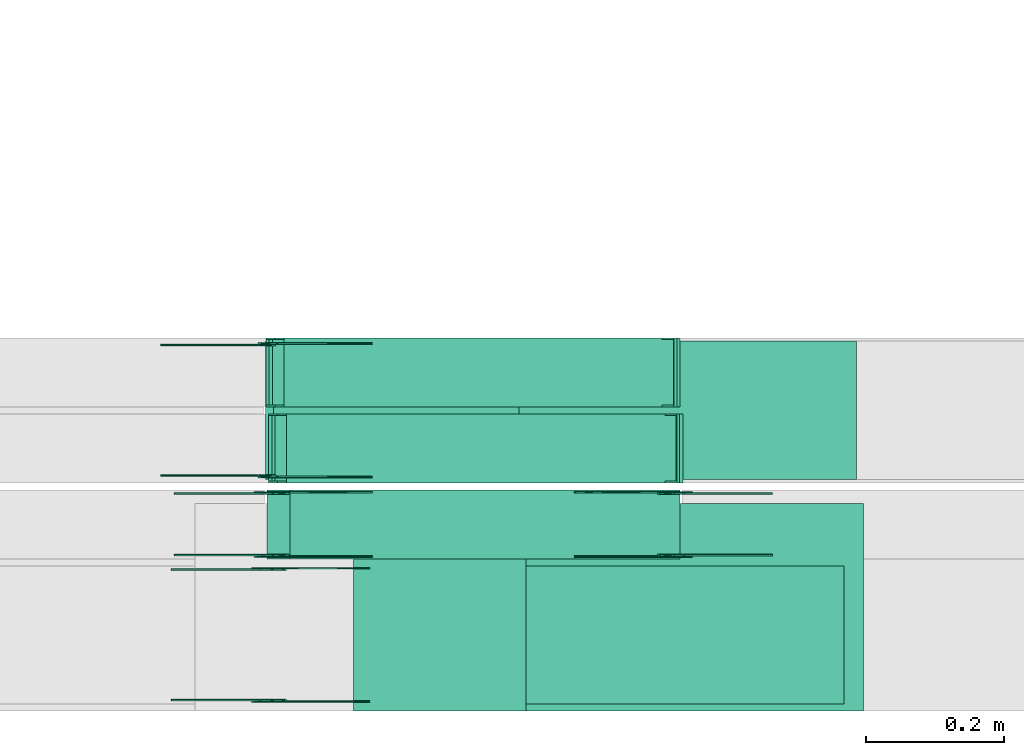
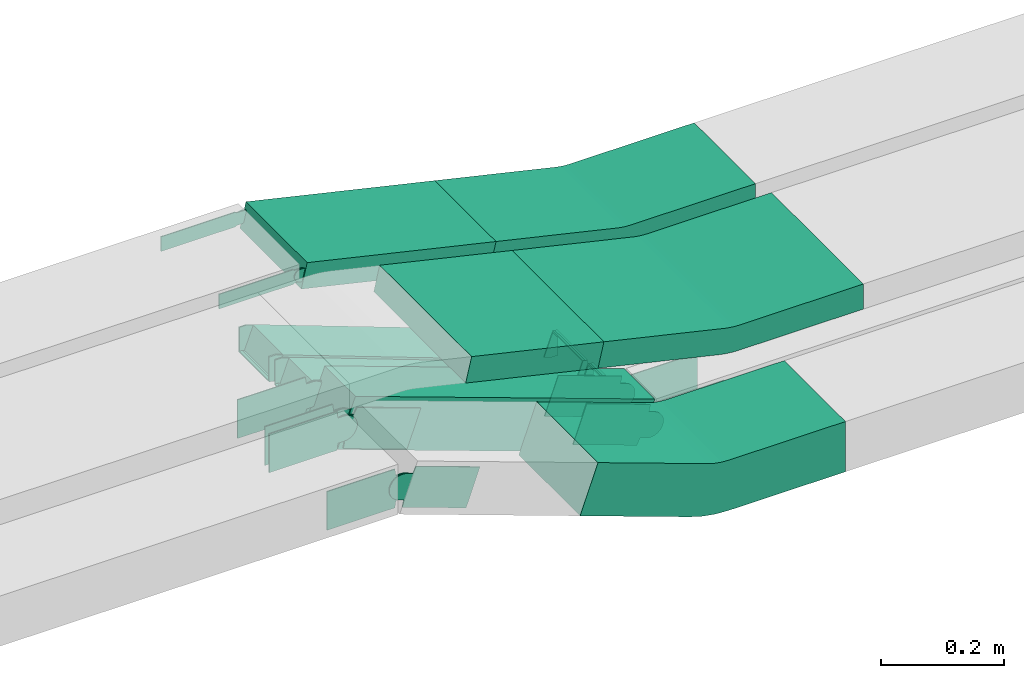
# One storey, part 13 of 31: 23 flow fittings, 5 flow segments.
"""IFC2X3 building model written with IfcOpenShell, lengths in millimetres."""

from ifc_helpers import new_model, entity, si_unit, converted_unit, derived_unit, direction, frame, frame_2d, origin, origin_2d_with_axis, place, context, subcontext, project, spatial, polyline, circle_curve, parameter, trimmed, segment, composite_curve, rectangle, outline, extrude, faceted_brep, source, transform, mapped, material, type_object, type_shapes, element, save


model = new_model("IFC2X3")

# Units and contexts
model_context = context("Model", 3, precision=0.01, world=origin(), true_north=direction((6.12303176911189e-17, 1.0)))
body_context = subcontext(model_context, "Body", "Model", "MODEL_VIEW")
ifc_project = project(units=[si_unit("LENGTHUNIT", "METRE", prefix="MILLI"), si_unit("AREAUNIT", "SQUARE_METRE"), si_unit("VOLUMEUNIT", "CUBIC_METRE"), converted_unit("PLANEANGLEUNIT", "DEGREE", entity("IfcRatioMeasure", 0.0174532925199433), si_unit("PLANEANGLEUNIT", "RADIAN"), dimensions=[0, 0, 0, 0, 0, 0, 0]), si_unit("MASSUNIT", "GRAM", prefix="KILO"), derived_unit("MASSDENSITYUNIT", [(si_unit("MASSUNIT", "GRAM", prefix="KILO"), 1), (si_unit("LENGTHUNIT", "METRE"), -3)]), derived_unit("MOMENTOFINERTIAUNIT", [(si_unit("LENGTHUNIT", "METRE"), 4)]), si_unit("TIMEUNIT", "SECOND"), si_unit("FREQUENCYUNIT", "HERTZ"), si_unit("THERMODYNAMICTEMPERATUREUNIT", "DEGREE_CELSIUS"), derived_unit("THERMALTRANSMITTANCEUNIT", [(si_unit("MASSUNIT", "GRAM", prefix="KILO"), 1), (si_unit("THERMODYNAMICTEMPERATUREUNIT", "KELVIN"), -1), (si_unit("TIMEUNIT", "SECOND"), -3)]), derived_unit("VOLUMETRICFLOWRATEUNIT", [(si_unit("LENGTHUNIT", "METRE"), 3), (si_unit("TIMEUNIT", "SECOND"), -1)]), derived_unit("MASSFLOWRATEUNIT", [(si_unit("MASSUNIT", "GRAM", prefix="KILO"), 1), (si_unit("TIMEUNIT", "SECOND"), -1)]), derived_unit("ROTATIONALFREQUENCYUNIT", [(si_unit("TIMEUNIT", "SECOND"), -1)]), si_unit("ELECTRICCURRENTUNIT", "AMPERE"), si_unit("ELECTRICVOLTAGEUNIT", "VOLT"), si_unit("POWERUNIT", "WATT"), si_unit("FORCEUNIT", "NEWTON", prefix="KILO"), si_unit("ILLUMINANCEUNIT", "LUX"), si_unit("LUMINOUSFLUXUNIT", "LUMEN"), si_unit("LUMINOUSINTENSITYUNIT", "CANDELA"), derived_unit("USERDEFINED", [(si_unit("MASSUNIT", "GRAM", prefix="KILO"), -1), (si_unit("LENGTHUNIT", "METRE"), -2), (si_unit("TIMEUNIT", "SECOND"), 3), (si_unit("LUMINOUSFLUXUNIT", "LUMEN"), 1)]), derived_unit("LINEARVELOCITYUNIT", [(si_unit("LENGTHUNIT", "METRE"), 1), (si_unit("TIMEUNIT", "SECOND"), -1)]), si_unit("PRESSUREUNIT", "PASCAL"), derived_unit("USERDEFINED", [(si_unit("LENGTHUNIT", "METRE"), -2), (si_unit("MASSUNIT", "GRAM", prefix="KILO"), 1), (si_unit("TIMEUNIT", "SECOND"), -2)]), derived_unit("LINEARFORCEUNIT", [(si_unit("MASSUNIT", "GRAM", prefix="KILO"), 1), (si_unit("LENGTHUNIT", "METRE"), 1), (si_unit("TIMEUNIT", "SECOND"), -2), (si_unit("LENGTHUNIT", "METRE"), -1)]), derived_unit("PLANARFORCEUNIT", [(si_unit("MASSUNIT", "GRAM", prefix="KILO"), 1), (si_unit("LENGTHUNIT", "METRE"), 1), (si_unit("TIMEUNIT", "SECOND"), -2), (si_unit("LENGTHUNIT", "METRE"), -2)])], contexts=[model_context])

# Site, building, storey
site_placement = place(None, frame((0.0, -0.00077364408347762, 0.0)))
site = spatial("IfcSite", under=ifc_project, at=site_placement, CompositionType="ELEMENT")
building_placement = place(site_placement, origin())
building = spatial("IfcBuilding", under=site, at=building_placement, CompositionType="ELEMENT")
storey_placement = place(building_placement, frame((0.0, 0.0, 15900.0)))
storey = spatial("IfcBuildingStorey", under=building, at=storey_placement, CompositionType="ELEMENT", Elevation=15900.0)

# Flow segments
cable_carrier_segment_type = type_object("IfcCableCarrierSegmentType", PredefinedType="CABLETRAYSEGMENT")
flow_segment_1_placement = place(storey_placement, frame((42482.3180305908, 8215.14880665484, 2877.20647019487)))
element("IfcFlowSegment", 1, at=flow_segment_1_placement, inside=storey, type_object=cable_carrier_segment_type, context=body_context, shape_type="SweptSolid", body=[
    extrude(rectangle(XDim=49.9999999999981, YDim=255.770491519839, at=frame_2d((0.0, 0.0), x_axis=(0.0, 1.0))), frame((130.22711908791, 0.0, 53.2392767577453), z_axis=(0.0, 1.0, 0.0), x_axis=(-0.974157642890838, 0.0, 0.225869180716108)), (0.0, 0.0, 1.0), 299.999999999999),
])
flow_segment_2_placement = place(storey_placement, frame((42367.697045461, 8434.96624585786, 2506.47701991748)))
element("IfcFlowSegment", 2, at=flow_segment_2_placement, inside=storey, type_object=cable_carrier_segment_type, context=body_context, shape_type="SweptSolid", body=[
    extrude(rectangle(XDim=100.000000000003, YDim=99.9999999999989, at=origin_2d_with_axis()), frame((16.9237303605876, 50.0, 249.997183871926), z_axis=(0.940975525862782, 0.0, -0.338474607211915), x_axis=(0.338474607211915, 0.0, 0.940975525862782)), (0.0, 0.0, 1.0), 599.59714334412),
])
flow_segment_3_placement = place(storey_placement, frame((42366.014324896, 8550.14880665484, 2877.20647019487)))
element("IfcFlowSegment", 3, at=flow_segment_3_placement, inside=storey, type_object=cable_carrier_segment_type, context=body_context, shape_type="SweptSolid", body=[
    extrude(rectangle(XDim=50.0000000000021, YDim=200.0, at=frame_2d((-9.78772618509538e-13, 1.08713038571295e-12), x_axis=(1.0, 0.0))), frame((5.6467295179074, 100.0, 106.818232268258), z_axis=(0.974157642890797, 0.0, -0.225869180716286), x_axis=(0.225869180716286, 0.0, 0.974157642890797)), (0.0, 0.0, 1.0), 365.097579645558),
])
flow_segment_4_placement = place(storey_placement, frame((42378.6912123669, 8544.96624585788, 2499.72488286839)))
element("IfcFlowSegment", 4, at=flow_segment_4_placement, inside=storey, type_object=cable_carrier_segment_type, context=body_context, shape_type="SweptSolid", body=[
    extrude(rectangle(XDim=50.0000000000049, YDim=100.000000000001, at=frame_2d((-1.01429975529754e-12, 0.0), x_axis=(1.0, 0.0))), frame((8.68410762290543, 50.0, 232.798975562678), z_axis=(0.937730259547007, 0.0, -0.347364304916183), x_axis=(0.347364304916183, 0.0, 0.937730259547007)), (0.0, 0.0, 1.0), 602.697848083628),
])
flow_segment_5_placement = place(storey_placement, frame((42374.9501718794, 8654.96624585788, 2499.69389983)))
element("IfcFlowSegment", 5, at=flow_segment_5_placement, inside=storey, type_object=cable_carrier_segment_type, context=body_context, shape_type="SweptSolid", body=[
    extrude(rectangle(XDim=50.0000000000049, YDim=100.000000000001, at=frame_2d((-1.01429975529754e-12, 0.0), x_axis=(1.0, 0.0))), frame((8.68410762289677, 50.0, 232.794724098533), z_axis=(0.937730259547007, 0.0, -0.347364304916183), x_axis=(0.347364304916183, 0.0, 0.937730259547007)), (0.0, 0.0, 1.0), 602.685608875145),
])

# Flow fittings
ifc_material_1 = material()
cable_carrier_fitting_type_1 = type_object("IfcCableCarrierFittingType", Name="470_DKC_S5_CS 90 internal vertical angle:-", PredefinedType="NOTDEFINED", material=ifc_material_1)
shared_shape_1 = source(origin(), body_context, "Body", "SweptSolid", [
    extrude(outline(composite_curve([segment(polyline([(-248.690961479511, -40.0445853156089), (-14.2965164116635, -40.0445853156089)]), True, "CONTINUOUS"), segment(trimmed(circle_curve(frame_2d((-14.2965164116638, 124.95541468439), x_axis=(0.0, -1.0)), 164.999999999999), [parameter(0.0)], [parameter(13.0539943692735)], True, "PARAMETER"), True, "CONTINUOUS"), segment(polyline([(22.9718984064878, -35.7805963925986), (251.309038520489, 17.1618848792738)]), True, "CONTINUOUS"), segment(polyline([(251.309038520489, 17.1618848792738), (240.015579484686, 65.8697670238164)]), True, "CONTINUOUS"), segment(polyline([(240.015579484686, 65.8697670238164), (11.6784393706841, 12.927285751944)]), True, "CONTINUOUS"), segment(trimmed(circle_curve(frame_2d((-14.2965164116638, 124.95541468439), x_axis=(0.0, -1.0)), 114.999999999999), [parameter(0.0)], [parameter(13.0539943692735)], True, "PARAMETER"), False, "CONTINUOUS"), segment(polyline([(-14.2965164116635, 9.95541468439133), (-248.690961479511, 9.95541468439135)]), True, "CONTINUOUS"), segment(polyline([(-248.690961479511, 9.95541468439135), (-248.690961479511, -40.0445853156089)]), True, "CONTINUOUS")], self_intersect=False)), frame((-1.72129524289458, 15.0445853156017, -150.0)), (0.0, 0.0, 1.0), 300.0),
])
type_shapes(cable_carrier_fitting_type_1, [shared_shape_1])
flow_fitting_1_placement = place(storey_placement, frame((42981.0665530085, 8365.14880665484, 2845.0), z_axis=(0.0, 1.0, 0.0), x_axis=(-1.0, 0.0, 0.0)))
element("IfcFlowFitting", 6, at=flow_fitting_1_placement, inside=storey, type_object=cable_carrier_fitting_type_1, material=ifc_material_1, Name="470_DKC_S5_CS 90 internal vertical angle:-", ObjectType="470_DKC_S5_CS 90 internal vertical angle:-", context=body_context, shape_type="MappedRepresentation", body=[
    mapped(shared_shape_1, transform((0.0, 0.0, 0.0), scale=1.0)),
])
cable_carrier_fitting_type_2 = type_object("IfcCableCarrierFittingType", Name="470_DKC_S5_CS 90 internal vertical angle:-", PredefinedType="NOTDEFINED", material=ifc_material_1)
shared_shape_2 = source(origin(), body_context, "Body", "SweptSolid", [
    extrude(outline(composite_curve([segment(polyline([(-248.690961479511, -40.0445853156089), (-14.2965164116635, -40.0445853156089)]), True, "CONTINUOUS"), segment(trimmed(circle_curve(frame_2d((-14.2965164116638, 124.95541468439), x_axis=(0.0, -1.0)), 164.999999999999), [parameter(0.0)], [parameter(13.0539943692735)], True, "PARAMETER"), True, "CONTINUOUS"), segment(polyline([(22.9718984064878, -35.7805963925986), (251.309038520489, 17.1618848792738)]), True, "CONTINUOUS"), segment(polyline([(251.309038520489, 17.1618848792738), (240.015579484686, 65.8697670238164)]), True, "CONTINUOUS"), segment(polyline([(240.015579484686, 65.8697670238164), (11.6784393706841, 12.9272857519439)]), True, "CONTINUOUS"), segment(trimmed(circle_curve(frame_2d((-14.2965164116638, 124.95541468439), x_axis=(0.0, -1.0)), 114.999999999999), [parameter(0.0)], [parameter(13.0539943692735)], True, "PARAMETER"), False, "CONTINUOUS"), segment(polyline([(-14.2965164116635, 9.95541468439131), (-248.690961479511, 9.95541468439132)]), True, "CONTINUOUS"), segment(polyline([(-248.690961479511, 9.95541468439132), (-248.690961479511, -40.0445853156089)]), True, "CONTINUOUS")], self_intersect=False)), frame((-1.72129524289457, 15.0445853156016, -100.0)), (0.0, 0.0, 1.0), 200.0),
])
type_shapes(cable_carrier_fitting_type_2, [shared_shape_2])
flow_fitting_2_placement = place(storey_placement, frame((42971.2646657863, 8650.14880665484, 2845.0), z_axis=(0.0, 1.0, 0.0), x_axis=(-1.0, 0.0, 0.0)))
element("IfcFlowFitting", 7, at=flow_fitting_2_placement, inside=storey, type_object=cable_carrier_fitting_type_2, material=ifc_material_1, Name="470_DKC_S5_CS 90 internal vertical angle:-", ObjectType="470_DKC_S5_CS 90 internal vertical angle:-", context=body_context, shape_type="MappedRepresentation", body=[
    mapped(shared_shape_2, transform((0.0, 0.0, 0.0), scale=1.0)),
])
cable_carrier_fitting_type_3 = type_object("IfcCableCarrierFittingType", PredefinedType="NOTDEFINED", material=ifc_material_1)
shared_shape_3 = source(origin(), body_context, "Body", "Brep", [
    faceted_brep([(-8.96317491056018, 25.0, 50.0), (-8.96317491056018, 25.0, -50.0), (-8.96317491056034, -25.0, -50.0), (-8.96317491056034, -25.0, -47.4600000101565), (-8.96317491056018, 22.46000001016, -47.4600000101565), (-8.96317491056018, 22.46000001016, 47.4600000101635), (-8.96317491056034, -25.0, 47.4600000101635), (-8.96317491056034, -25.0, 50.0), (-0.279067287656983, 26.5567435113238, 50.0), (17.0891479581493, -20.3297694660276, 50.0), (17.0891479581493, -20.3297694660276, 47.4600000101635), (0.603238043300752, 24.1749086616017, 47.4600000101635), (0.60323804330075, 24.1749086616017, -47.4600000101565), (17.0891479581493, -20.3297694660276, -47.4600000101565), (17.0891479581493, -20.3297694660276, -50.0), (-0.279067287656982, 26.5567435113238, -50.0), (-4.48158745527978, 25.0, 50.0), (-4.48158745527987, 25.0, -50.0), (4.48158745528077, -25.0, -50.0), (4.48158745528077, -25.0, -47.4600000101565), (-4.0262581716447, 22.46000001016, -47.4600000101565), (-4.0262581716447, 22.46000001016, 47.4600000101635), (4.48158745528077, -25.0, 47.4600000101635), (4.48158745528077, -25.0, 50.0)], [[[0, 1, 2, 3, 4, 5, 6, 7]], [[8, 9, 10, 11, 12, 13, 14, 15]], [[1, 0, 16, 17]], [[2, 1, 17, 15, 14, 18]], [[3, 2, 18, 19]], [[4, 3, 19, 13, 12, 20]], [[5, 4, 20, 21]], [[6, 5, 21, 11, 10, 22]], [[7, 6, 22, 23]], [[0, 7, 23, 9, 8, 16]], [[17, 16, 8, 15]], [[19, 18, 14, 13]], [[21, 20, 12, 11]], [[23, 22, 10, 9]]]),
])
type_shapes(cable_carrier_fitting_type_3, [shared_shape_3])
for number, where, z_axis, x_axis in (
    (8, (42378.9702796546, 8594.96624585789, 2735.63734545371), (0.0, 1.0, 0.0), (1.0, 0.0, 0.0)),
    (9, (42375.229239167, 8704.96624585788, 2735.60211095118), (0.0, 1.0, 0.0), (1.0, 0.0, 0.0)),
    (10, (42960.948369837, 8594.96624585789, 2520.05465233443), (0.0, -1.0, 0.0), (0.937730259547021, 0.0, -0.347364304916146)),
    (11, (42957.1958522733, 8704.96624585788, 2520.02366929604), (0.0, -1.0, 0.0), (0.937730259547021, 0.0, -0.347364304916146)),
):
    element("IfcFlowFitting", number, at=place(storey_placement, frame(where, z_axis=z_axis, x_axis=x_axis)), inside=storey, type_object=cable_carrier_fitting_type_3, material=ifc_material_1, context=body_context, shape_type="MappedRepresentation", body=[
        mapped(shared_shape_3, transform((0.0, 0.0, 0.0), scale=1.0)),
    ])
ifc_material_2 = material(Name="G")
cable_carrier_fitting_type_4 = type_object("IfcCableCarrierFittingType", PredefinedType="NOTDEFINED", material=ifc_material_2)
shared_shape_4 = source(origin(), body_context, "Body", "SweptSolid", [
    extrude(outline(composite_curve([segment(trimmed(circle_curve(frame_2d((-44.5901162790698, 0.0), x_axis=(1.0, 0.0)), 12.5), [parameter(90.0000000000007)], [parameter(270.0)], True, "PARAMETER"), True, "CONTINUOUS"), segment(polyline([(-44.5901162790697, -12.5), (-33.0901162790698, -12.5)]), True, "CONTINUOUS"), segment(polyline([(-33.0901162790698, -12.5), (-31.2296511627907, -14.5)]), True, "CONTINUOUS"), segment(polyline([(-31.2296511627907, -14.5), (108.90988372093, -14.5)]), True, "CONTINUOUS"), segment(polyline([(108.90988372093, -14.5), (108.90988372093, 14.5)]), True, "CONTINUOUS"), segment(polyline([(108.90988372093, 14.5), (-31.2296511627907, 14.5)]), True, "CONTINUOUS"), segment(polyline([(-31.2296511627907, 14.5), (-33.0901162790698, 12.5)]), True, "CONTINUOUS"), segment(polyline([(-33.0901162790698, 12.5), (-44.5901162790699, 12.5)]), True, "CONTINUOUS")], self_intersect=False)), frame((44.5901162790698, 0.0, 0.0), z_axis=(0.0, 0.0, -1.0), x_axis=(1.0, 0.0, 0.0)), (0.0, 0.0, -1.0), 2.0),
])
type_shapes(cable_carrier_fitting_type_4, [shared_shape_4])
flow_fitting_3_placement = place(storey_placement, frame((42367.4546658015, 8745.608806665, 2985.0), z_axis=(0.0, 1.0, 0.0), x_axis=(0.974157642890837, 0.0, -0.225869180716116)))
element("IfcFlowFitting", 12, at=flow_fitting_3_placement, inside=storey, type_object=cable_carrier_fitting_type_4, material=ifc_material_2, context=body_context, shape_type="MappedRepresentation", body=[
    mapped(shared_shape_4, transform((0.0, 0.0, 0.0), scale=1.0)),
])
cable_carrier_fitting_type_5 = type_object("IfcCableCarrierFittingType", PredefinedType="NOTDEFINED", material=ifc_material_2)
shared_shape_5 = source(origin(), body_context, "Body", "SweptSolid", [
    extrude(outline(composite_curve([segment(trimmed(circle_curve(frame_2d((-44.5901162790697, 0.0), x_axis=(1.0, 0.0)), 12.5), [parameter(90.0000000000007)], [parameter(270.0)], True, "PARAMETER"), True, "CONTINUOUS"), segment(polyline([(-44.5901162790697, -12.5), (-33.0901162790697, -12.5)]), True, "CONTINUOUS"), segment(polyline([(-33.0901162790697, -12.5), (-31.2296511627907, -14.5)]), True, "CONTINUOUS"), segment(polyline([(-31.2296511627907, -14.5), (108.90988372093, -14.5)]), True, "CONTINUOUS"), segment(polyline([(108.90988372093, -14.5), (108.90988372093, 14.5)]), True, "CONTINUOUS"), segment(polyline([(108.90988372093, 14.5), (-31.2296511627907, 14.5)]), True, "CONTINUOUS"), segment(polyline([(-31.2296511627907, 14.5), (-33.0901162790698, 12.5)]), True, "CONTINUOUS"), segment(polyline([(-33.0901162790698, 12.5), (-44.5901162790699, 12.5)]), True, "CONTINUOUS")], self_intersect=False)), frame((44.5901162790697, 0.0, 0.0)), (0.0, 0.0, 1.0), 2.0),
])
type_shapes(cable_carrier_fitting_type_5, [shared_shape_5])
flow_fitting_4_placement = place(storey_placement, frame((42367.4546658015, 8554.68880664468, 2985.0), z_axis=(0.0, -1.0, 0.0), x_axis=(0.974157642890837, 0.0, -0.225869180716116)))
element("IfcFlowFitting", 13, at=flow_fitting_4_placement, inside=storey, type_object=cable_carrier_fitting_type_5, material=ifc_material_2, context=body_context, shape_type="MappedRepresentation", body=[
    mapped(shared_shape_5, transform((0.0, 0.0, 0.0), scale=1.0)),
])
cable_carrier_fitting_type_6 = type_object("IfcCableCarrierFittingType", PredefinedType="NOTDEFINED", material=ifc_material_2)
shared_shape_6 = source(origin(), body_context, "Body", "SweptSolid", [
    extrude(outline(composite_curve([segment(trimmed(circle_curve(frame_2d((-44.5901162790698, 0.0), x_axis=(1.0, 0.0)), 12.5), [parameter(90.0000000000007)], [parameter(270.0)], True, "PARAMETER"), True, "CONTINUOUS"), segment(polyline([(-44.5901162790697, -12.5), (-33.0901162790698, -12.5)]), True, "CONTINUOUS"), segment(polyline([(-33.0901162790698, -12.5), (-31.2296511627907, -14.5)]), True, "CONTINUOUS"), segment(polyline([(-31.2296511627907, -14.5), (108.90988372093, -14.5)]), True, "CONTINUOUS"), segment(polyline([(108.90988372093, -14.5), (108.90988372093, 14.5)]), True, "CONTINUOUS"), segment(polyline([(108.90988372093, 14.5), (-31.2296511627907, 14.5)]), True, "CONTINUOUS"), segment(polyline([(-31.2296511627907, 14.5), (-33.0901162790698, 12.5)]), True, "CONTINUOUS"), segment(polyline([(-33.0901162790698, 12.5), (-44.5901162790699, 12.5)]), True, "CONTINUOUS")], self_intersect=False)), frame((44.5901162790698, 0.0, 0.0), z_axis=(0.0, 0.0, -1.0), x_axis=(1.0, 0.0, 0.0)), (0.0, 0.0, -1.0), 2.0),
])
type_shapes(cable_carrier_fitting_type_6, [shared_shape_6])
flow_fitting_5_placement = place(storey_placement, frame((42367.4546658015, 8556.68880664468, 2985.0), z_axis=(0.0, -1.0, 0.0), x_axis=(-1.0, 0.0, 0.0)))
element("IfcFlowFitting", 14, at=flow_fitting_5_placement, inside=storey, type_object=cable_carrier_fitting_type_6, material=ifc_material_2, context=body_context, shape_type="MappedRepresentation", body=[
    mapped(shared_shape_6, transform((0.0, 0.0, 0.0), scale=1.0)),
])
cable_carrier_fitting_type_7 = type_object("IfcCableCarrierFittingType", PredefinedType="NOTDEFINED", material=ifc_material_2)
shared_shape_7 = source(origin(), body_context, "Body", "SweptSolid", [
    extrude(outline(composite_curve([segment(trimmed(circle_curve(frame_2d((-44.5901162790697, 0.0), x_axis=(1.0, 0.0)), 12.5), [parameter(90.0000000000007)], [parameter(270.0)], True, "PARAMETER"), True, "CONTINUOUS"), segment(polyline([(-44.5901162790697, -12.5), (-33.0901162790697, -12.5)]), True, "CONTINUOUS"), segment(polyline([(-33.0901162790697, -12.5), (-31.2296511627907, -14.5)]), True, "CONTINUOUS"), segment(polyline([(-31.2296511627907, -14.5), (108.90988372093, -14.5)]), True, "CONTINUOUS"), segment(polyline([(108.90988372093, -14.5), (108.90988372093, 14.5)]), True, "CONTINUOUS"), segment(polyline([(108.90988372093, 14.5), (-31.2296511627907, 14.5)]), True, "CONTINUOUS"), segment(polyline([(-31.2296511627907, 14.5), (-33.0901162790698, 12.5)]), True, "CONTINUOUS"), segment(polyline([(-33.0901162790698, 12.5), (-44.5901162790699, 12.5)]), True, "CONTINUOUS")], self_intersect=False)), frame((44.5901162790697, 0.0, 0.0)), (0.0, 0.0, 1.0), 2.0),
])
type_shapes(cable_carrier_fitting_type_7, [shared_shape_7])
flow_fitting_6_placement = place(storey_placement, frame((42367.4546658015, 8743.608806665, 2985.0), z_axis=(0.0, 1.0, 0.0), x_axis=(-1.0, 0.0, 0.0)))
element("IfcFlowFitting", 15, at=flow_fitting_6_placement, inside=storey, type_object=cable_carrier_fitting_type_7, material=ifc_material_2, context=body_context, shape_type="MappedRepresentation", body=[
    mapped(shared_shape_7, transform((0.0, 0.0, 0.0), scale=1.0)),
])
cable_carrier_fitting_type_8 = type_object("IfcCableCarrierFittingType", Name="470_DKC_S5_CS 90 internal vertical angle:-", PredefinedType="NOTDEFINED", material=ifc_material_1)
shared_shape_8 = source(origin(), body_context, "Body", "SweptSolid", [
    extrude(outline(composite_curve([segment(polyline([(-244.786102826925, -73.4949234346323), (-24.6761870877569, -73.4949234346323)]), True, "CONTINUOUS"), segment(trimmed(circle_curve(frame_2d((-24.6761870877573, 141.505076565367), x_axis=(0.0, -1.0)), 214.999999999999), [parameter(0.0)], [parameter(19.7839661238225)], True, "PARAMETER"), True, "CONTINUOUS"), segment(polyline([(48.0958534627945, -60.804661495134), (255.213897173075, 13.6969557781184)]), True, "CONTINUOUS"), segment(polyline([(255.213897173074, 13.6969557781183), (221.366436451887, 107.794508364399)]), True, "CONTINUOUS"), segment(polyline([(221.366436451888, 107.794508364399), (14.2483927416074, 33.292891091146)]), True, "CONTINUOUS"), segment(trimmed(circle_curve(frame_2d((-24.6761870877573, 141.505076565367), x_axis=(0.0, -1.0)), 114.999999999999), [parameter(0.0)], [parameter(19.7839661238225)], True, "PARAMETER"), False, "CONTINUOUS"), segment(polyline([(-24.6761870877569, 26.5050765653679), (-244.786102826925, 26.505076565368)]), True, "CONTINUOUS"), segment(polyline([(-244.786102826925, 26.505076565368), (-244.786102826925, -73.4949234346323)]), True, "CONTINUOUS")], self_intersect=False)), frame((-4.09713305244168, 23.494923434625, -100.0)), (0.0, 0.0, 1.0), 200.0),
])
type_shapes(cable_carrier_fitting_type_8, [shared_shape_8])
flow_fitting_7_placement = place(storey_placement, frame((42954.5779725413, 8324.96624585788, 2550.0), z_axis=(0.0, -1.0, 0.0), x_axis=(0.940975525862787, 0.0, -0.338474607211903)))
element("IfcFlowFitting", 16, at=flow_fitting_7_placement, inside=storey, type_object=cable_carrier_fitting_type_8, material=ifc_material_1, Name="470_DKC_S5_CS 90 internal vertical angle:-", ObjectType="470_DKC_S5_CS 90 internal vertical angle:-", context=body_context, shape_type="MappedRepresentation", body=[
    mapped(shared_shape_8, transform((0.0, 0.0, 0.0), scale=1.0)),
])
cable_carrier_fitting_type_9 = type_object("IfcCableCarrierFittingType", PredefinedType="NOTDEFINED", material=ifc_material_2)
shared_shape_9 = source(origin(), body_context, "Body", "SweptSolid", [
    extrude(outline(composite_curve([segment(trimmed(circle_curve(frame_2d((-41.4651162790697, 0.0), x_axis=(1.0, 0.0)), 25.0), [parameter(90.0000000000007)], [parameter(270.0)], True, "PARAMETER"), True, "CONTINUOUS"), segment(polyline([(-41.4651162790697, -25.0), (-29.9651162790697, -25.0)]), True, "CONTINUOUS"), segment(polyline([(-29.9651162790697, -25.0), (-28.1046511627907, -38.5)]), True, "CONTINUOUS"), segment(polyline([(-28.1046511627907, -38.5), (99.5348837209303, -38.5)]), True, "CONTINUOUS"), segment(polyline([(99.5348837209303, -38.5), (99.5348837209303, 38.5)]), True, "CONTINUOUS"), segment(polyline([(99.5348837209303, 38.5), (-28.1046511627907, 38.5)]), True, "CONTINUOUS"), segment(polyline([(-28.1046511627907, 38.5), (-29.9651162790697, 25.0)]), True, "CONTINUOUS"), segment(polyline([(-29.9651162790697, 25.0), (-41.46511627907, 25.0)]), True, "CONTINUOUS")], self_intersect=False)), frame((41.4651162790697, 0.0, 0.0), z_axis=(0.0, 0.0, -1.0), x_axis=(1.0, 0.0, 0.0)), (0.0, 0.0, -1.0), 2.0),
])
type_shapes(cable_carrier_fitting_type_9, [shared_shape_9])
for number, where, z_axis, x_axis in (
    (17, (42374.8188944612, 8530.42624586802, 2760.0), (0.0, 1.0, 0.0), (0.940975525862779, 0.0, -0.338474607211925)),
    (18, (42958.628894446, 8530.42624586802, 2550.0), (0.0, 1.0, 0.0), (-0.940975525862779, 0.0, 0.338474607211925)),
    (19, (42370.7679725565, 8420.42624586803, 2760.0), (0.0, 1.0, 0.0), (0.940975525862787, 0.0, -0.338474607211903)),
):
    element("IfcFlowFitting", number, at=place(storey_placement, frame(where, z_axis=z_axis, x_axis=x_axis)), inside=storey, type_object=cable_carrier_fitting_type_9, material=ifc_material_2, context=body_context, shape_type="MappedRepresentation", body=[
        mapped(shared_shape_9, transform((0.0, 0.0, 0.0), scale=1.0)),
    ])
cable_carrier_fitting_type_10 = type_object("IfcCableCarrierFittingType", PredefinedType="NOTDEFINED", material=ifc_material_2)
shared_shape_10 = source(origin(), body_context, "Body", "SweptSolid", [
    extrude(outline(composite_curve([segment(trimmed(circle_curve(frame_2d((-41.4651162790697, 0.0), x_axis=(1.0, 0.0)), 25.0), [parameter(90.0000000000007)], [parameter(270.0)], True, "PARAMETER"), True, "CONTINUOUS"), segment(polyline([(-41.4651162790697, -25.0), (-29.9651162790697, -25.0)]), True, "CONTINUOUS"), segment(polyline([(-29.9651162790697, -25.0), (-28.1046511627907, -38.5)]), True, "CONTINUOUS"), segment(polyline([(-28.1046511627907, -38.5), (99.5348837209303, -38.5)]), True, "CONTINUOUS"), segment(polyline([(99.5348837209303, -38.5), (99.5348837209303, 38.5)]), True, "CONTINUOUS"), segment(polyline([(99.5348837209303, 38.5), (-28.1046511627907, 38.5)]), True, "CONTINUOUS"), segment(polyline([(-28.1046511627907, 38.5), (-29.9651162790697, 25.0)]), True, "CONTINUOUS"), segment(polyline([(-29.9651162790697, 25.0), (-41.46511627907, 25.0)]), True, "CONTINUOUS")], self_intersect=False)), frame((41.4651162790697, 0.0, 0.0)), (0.0, 0.0, 1.0), 2.0),
])
type_shapes(cable_carrier_fitting_type_10, [shared_shape_10])
for number, where, z_axis, x_axis in (
    (20, (42374.8188944612, 8439.5062458477, 2760.0), (0.0, -1.0, 0.0), (0.940975525862779, 0.0, -0.338474607211925)),
    (21, (42958.628894446, 8439.5062458477, 2550.0), (0.0, -1.0, 0.0), (-0.940975525862779, 0.0, 0.338474607211925)),
    (22, (42370.7679725565, 8229.50624584771, 2760.0), (0.0, -1.0, 0.0), (0.940975525862787, 0.0, -0.338474607211903)),
):
    element("IfcFlowFitting", number, at=place(storey_placement, frame(where, z_axis=z_axis, x_axis=x_axis)), inside=storey, type_object=cable_carrier_fitting_type_10, material=ifc_material_2, context=body_context, shape_type="MappedRepresentation", body=[
        mapped(shared_shape_10, transform((0.0, 0.0, 0.0), scale=1.0)),
    ])
cable_carrier_fitting_type_11 = type_object("IfcCableCarrierFittingType", PredefinedType="NOTDEFINED", material=ifc_material_2)
shared_shape_11 = source(origin(), body_context, "Body", "SweptSolid", [
    extrude(outline(composite_curve([segment(trimmed(circle_curve(frame_2d((-41.4651162790697, 0.0), x_axis=(1.0, 0.0)), 25.0), [parameter(90.0000000000007)], [parameter(270.0)], True, "PARAMETER"), True, "CONTINUOUS"), segment(polyline([(-41.4651162790697, -25.0), (-29.9651162790697, -25.0)]), True, "CONTINUOUS"), segment(polyline([(-29.9651162790697, -25.0), (-28.1046511627907, -38.5)]), True, "CONTINUOUS"), segment(polyline([(-28.1046511627907, -38.5), (99.5348837209303, -38.5)]), True, "CONTINUOUS"), segment(polyline([(99.5348837209303, -38.5), (99.5348837209303, 38.5)]), True, "CONTINUOUS"), segment(polyline([(99.5348837209303, 38.5), (-28.1046511627907, 38.5)]), True, "CONTINUOUS"), segment(polyline([(-28.1046511627907, 38.5), (-29.9651162790697, 25.0)]), True, "CONTINUOUS"), segment(polyline([(-29.9651162790697, 25.0), (-41.46511627907, 25.0)]), True, "CONTINUOUS")], self_intersect=False)), frame((41.4651162790697, 0.0, 0.0), z_axis=(0.0, 0.0, -1.0), x_axis=(1.0, 0.0, 0.0)), (0.0, 0.0, -1.0), 2.0),
])
type_shapes(cable_carrier_fitting_type_11, [shared_shape_11])
for number, where, z_axis, x_axis in (
    (23, (42374.8188944613, 8441.5062458477, 2760.0), (0.0, -1.0, 0.0), (-1.0, 0.0, 0.0)),
    (24, (42958.628894446, 8441.5062458477, 2550.0), (0.0, -1.0, 0.0), (1.0, 0.0, 0.0)),
    (25, (42370.7679725565, 8231.50624584771, 2760.0), (0.0, -1.0, 0.0), (-1.0, 0.0, 0.0)),
):
    element("IfcFlowFitting", number, at=place(storey_placement, frame(where, z_axis=z_axis, x_axis=x_axis)), inside=storey, type_object=cable_carrier_fitting_type_11, material=ifc_material_2, context=body_context, shape_type="MappedRepresentation", body=[
        mapped(shared_shape_11, transform((0.0, 0.0, 0.0), scale=1.0)),
    ])
cable_carrier_fitting_type_12 = type_object("IfcCableCarrierFittingType", PredefinedType="NOTDEFINED", material=ifc_material_2)
shared_shape_12 = source(origin(), body_context, "Body", "SweptSolid", [
    extrude(outline(composite_curve([segment(trimmed(circle_curve(frame_2d((-41.4651162790697, 0.0), x_axis=(1.0, 0.0)), 25.0), [parameter(90.0000000000007)], [parameter(270.0)], True, "PARAMETER"), True, "CONTINUOUS"), segment(polyline([(-41.4651162790697, -25.0), (-29.9651162790697, -25.0)]), True, "CONTINUOUS"), segment(polyline([(-29.9651162790697, -25.0), (-28.1046511627907, -38.5)]), True, "CONTINUOUS"), segment(polyline([(-28.1046511627907, -38.5), (99.5348837209303, -38.5)]), True, "CONTINUOUS"), segment(polyline([(99.5348837209303, -38.5), (99.5348837209303, 38.5)]), True, "CONTINUOUS"), segment(polyline([(99.5348837209303, 38.5), (-28.1046511627907, 38.5)]), True, "CONTINUOUS"), segment(polyline([(-28.1046511627907, 38.5), (-29.9651162790697, 25.0)]), True, "CONTINUOUS"), segment(polyline([(-29.9651162790697, 25.0), (-41.46511627907, 25.0)]), True, "CONTINUOUS")], self_intersect=False)), frame((41.4651162790697, 0.0, 0.0)), (0.0, 0.0, 1.0), 2.0),
])
type_shapes(cable_carrier_fitting_type_12, [shared_shape_12])
for number, where, z_axis, x_axis in (
    (26, (42374.8188944613, 8528.42624586802, 2760.0), (0.0, 1.0, 0.0), (-1.0, 0.0, 0.0)),
    (27, (42958.628894446, 8528.42624586802, 2550.0), (0.0, 1.0, 0.0), (1.0, 0.0, 0.0)),
    (28, (42370.7679725565, 8418.42624586803, 2760.0), (0.0, 1.0, 0.0), (-1.0, 0.0, 0.0)),
):
    element("IfcFlowFitting", number, at=place(storey_placement, frame(where, z_axis=z_axis, x_axis=x_axis)), inside=storey, type_object=cable_carrier_fitting_type_12, material=ifc_material_2, context=body_context, shape_type="MappedRepresentation", body=[
        mapped(shared_shape_12, transform((0.0, 0.0, 0.0), scale=1.0)),
    ])

save(model, "model.ifc")
